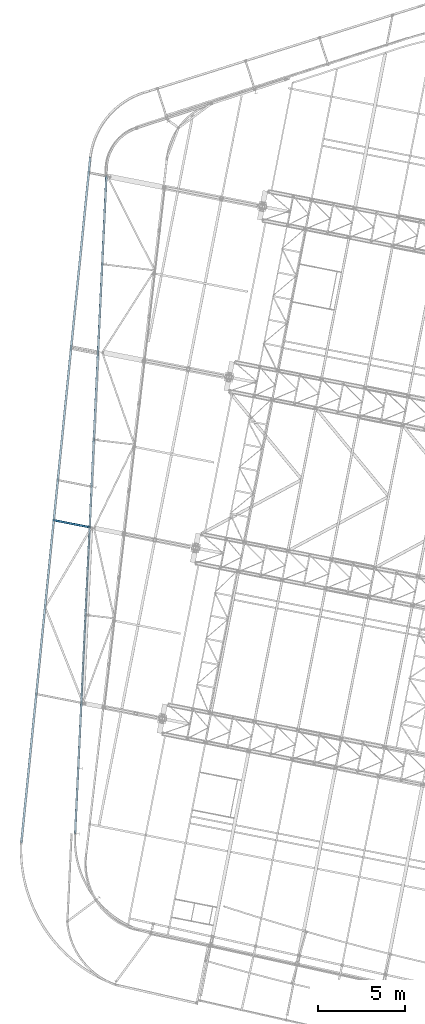
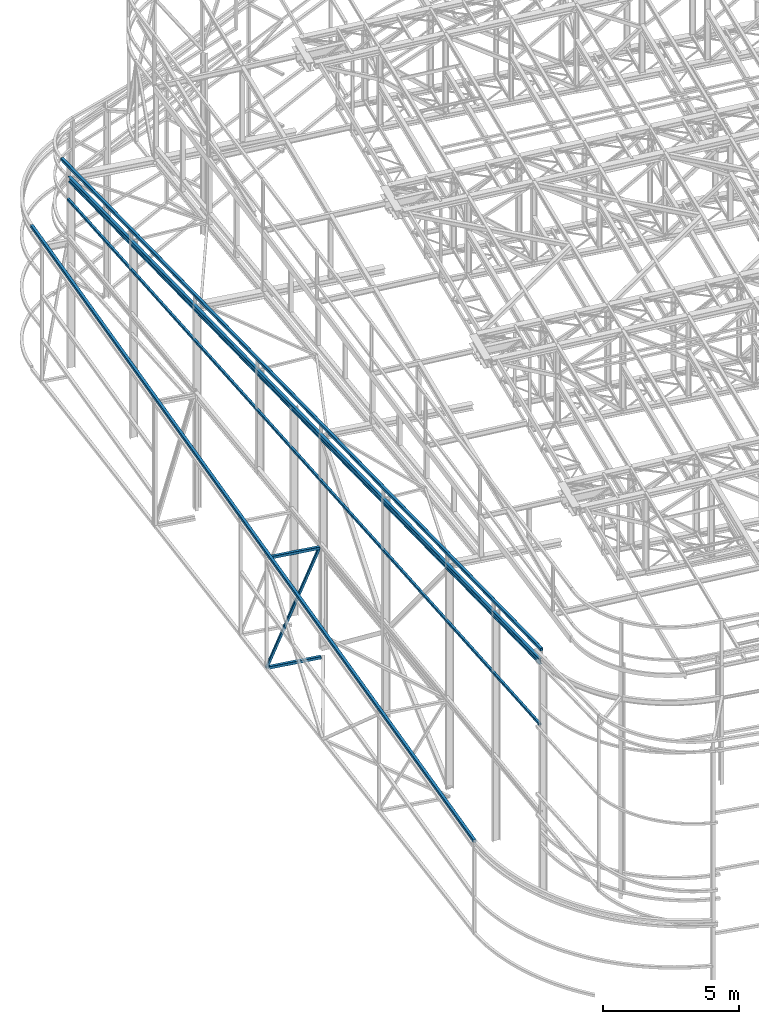
# One storey, part 64 of 215: 6 beams, 1 member, 7 elements without a shape of their own.
"""IFC2X3 building model written with IfcOpenShell, lengths in millimetres."""

from ifc_helpers import new_model, si_unit, frame, origin_with_axes, origin_2d_with_axis, place, context, subcontext, project, spatial, hollow_rectangle, i_section, extrude, material, type_object, element, aggregate, save


model = new_model("IFC2X3")

# Units and contexts
model_context = context("Model", 3, precision=1e-05, world=origin_with_axes())
body_context = subcontext(model_context, "Body", "Model", "MODEL_VIEW")
ifc_project = project(units=[si_unit("LENGTHUNIT", "METRE", prefix="MILLI"), si_unit("AREAUNIT", "SQUARE_METRE"), si_unit("VOLUMEUNIT", "CUBIC_METRE"), si_unit("MASSUNIT", "GRAM", prefix="KILO"), si_unit("TIMEUNIT", "SECOND"), si_unit("PLANEANGLEUNIT", "RADIAN"), si_unit("SOLIDANGLEUNIT", "STERADIAN"), si_unit("THERMODYNAMICTEMPERATUREUNIT", "DEGREE_CELSIUS"), si_unit("LUMINOUSINTENSITYUNIT", "LUMEN")], contexts=[model_context])

# Site, building, storey
site_placement = place(None, origin_with_axes())
site = spatial("IfcSite", under=ifc_project, at=site_placement, CompositionType="ELEMENT")
building_placement = place(site_placement, origin_with_axes())
building = spatial("IfcBuilding", under=site, at=building_placement, Name="Undefined", CompositionType="ELEMENT")
storey_placement = place(building_placement, origin_with_axes())
storey = spatial("IfcBuildingStorey", under=building, at=storey_placement, Name="Undefined", CompositionType="ELEMENT", Elevation=0.0)

# Assembly, beam
assembly_1_placement = place(storey_placement, origin_with_axes())
assembly_1 = element("IfcElementAssembly", 1, at=assembly_1_placement, inside=storey, Name="Steel Assembly", AssemblyPlace="NOTDEFINED", PredefinedType="RIGID_FRAME")
ifc_material = material(Name="STEEL/S275JR")
beam_type_1 = type_object("IfcBeamType", Name="IPE240", PredefinedType="NOTDEFINED")
beam_1_placement = place(assembly_1_placement, frame((37244.8718975773, 16568.7108386803, 10402.3701338187), z_axis=(0.00235880600061508, 0.0493175830129321, 0.998780362261901), x_axis=(0.0475433059778084, 0.99764815753433, -0.0493739589769538)))
beam_1 = element("IfcBeam", 2, at=beam_1_placement, type_object=beam_type_1, material=ifc_material, Name="LISSE", ObjectType="IPE240", context=body_context, shape_type="SweptSolid", body=[
    extrude(i_section(OverallWidth=120.0, OverallDepth=240.0, WebThickness=6.199999809, FlangeThickness=9.800000191, FilletRadius=15.0, at=origin_2d_with_axis()), frame((37819.5155899821, -1.47177935104382e-13, -2.62425606176051e-13), z_axis=(-1.0, 0.0, 0.0), x_axis=(-6.93889390390723e-18, -1.0, -3.46944695195361e-18)), (0.0, 0.0, 1.0), 37819.5),
])
aggregate(assembly_1, [beam_1])

assembly_2_placement = place(storey_placement, origin_with_axes())
assembly_2 = element("IfcElementAssembly", 3, at=assembly_2_placement, inside=storey, Name="Steel Assembly", AssemblyPlace="NOTDEFINED", PredefinedType="RIGID_FRAME")
beam_type_2 = type_object("IfcBeamType", PredefinedType="NOTDEFINED")
beam_2_placement = place(assembly_2_placement, frame((34149.1191373452, 16048.7739430814, 3742.45813808884), z_axis=(0.994981514571063, -0.100058910956865, 0.0), x_axis=(0.0998888689606629, 0.993290622608835, 0.0582748049770509)))
beam_2 = element("IfcBeam", 4, at=beam_2_placement, type_object=beam_type_2, material=ifc_material, Name="LISSE", context=body_context, shape_type="SweptSolid", body=[
    extrude(hollow_rectangle(XDim=120.0, YDim=120.0, WallThickness=4.0, InnerFilletRadius=4.0, OuterFilletRadius=8.0, at=origin_2d_with_axis()), frame((39666.4637966155, 4.54747350886464e-13, -2.49233572426971e-13), z_axis=(-1.0, 0.0, 0.0), x_axis=(-6.93889390390723e-18, -1.0, -3.46944695195361e-18)), (0.0, 0.0, 1.0), 39666.5),
])
aggregate(assembly_2, [beam_2])

assembly_3_placement = place(storey_placement, origin_with_axes())
assembly_3 = element("IfcElementAssembly", 5, at=assembly_3_placement, inside=storey, Name="Steel Assembly", AssemblyPlace="NOTDEFINED", PredefinedType="RIGID_FRAME")
beam_3_placement = place(assembly_3_placement, frame((37240.9799916972, 16485.8746585333, 10991.8441871799), z_axis=(0.998870920963872, -0.0474969269982821, -0.000961861999965319), x_axis=(0.0473891229994004, 0.997618619987376, -0.0501134719993658)))
beam_3 = element("IfcBeam", 6, at=beam_3_placement, type_object=beam_type_2, material=ifc_material, Name="LISSE", context=body_context, shape_type="SweptSolid", body=[
    extrude(hollow_rectangle(XDim=120.0, YDim=120.0, WallThickness=4.0, InnerFilletRadius=4.0, OuterFilletRadius=8.0, at=origin_2d_with_axis()), frame((38483.0306597107, 1.55195973669731e-12, 9.49207018875676e-14), z_axis=(-1.0, 0.0, 0.0), x_axis=(-6.93889390390723e-18, -1.0, -3.46944695195361e-18)), (0.0, 0.0, 1.0), 38483.0),
])
aggregate(assembly_3, [beam_3])

assembly_4_placement = place(storey_placement, origin_with_axes())
assembly_4 = element("IfcElementAssembly", 7, at=assembly_4_placement, inside=storey, Name="Steel Assembly", AssemblyPlace="NOTDEFINED", PredefinedType="RIGID_FRAME")
beam_type_3 = type_object("IfcBeamType", PredefinedType="NOTDEFINED")
beam_4_placement = place(assembly_4_placement, frame((36077.572611903, 34575.0879245013, -375.378507601517), z_axis=(0.0, 0.0, 1.0), x_axis=(0.981422409205525, -0.19185946604018, 1.89999991602007e-08)))
beam_4 = element("IfcBeam", 8, at=beam_4_placement, type_object=beam_type_3, material=ifc_material, Name="POUTRE", context=body_context, shape_type="SweptSolid", body=[
    extrude(hollow_rectangle(XDim=120.0, YDim=120.0, WallThickness=5.0, InnerFilletRadius=5.0, OuterFilletRadius=10.0, at=origin_2d_with_axis()), frame((2047.58475878097, -5.68318936017544e-14, 0.0), z_axis=(-1.0, 0.0, 0.0), x_axis=(-6.93889390390723e-18, -1.0, -3.46944695195361e-18)), (0.0, 0.0, 1.0), 2047.6),
])
aggregate(assembly_4, [beam_4])

assembly_5_placement = place(storey_placement, origin_with_axes())
assembly_5 = element("IfcElementAssembly", 9, at=assembly_5_placement, inside=storey, Name="Steel Assembly", AssemblyPlace="NOTDEFINED", PredefinedType="RIGID_FRAME")
beam_5_placement = place(assembly_5_placement, frame((36077.5332269981, 34574.9691921142, 4547.03321998367), z_axis=(0.0, 0.0, 1.0), x_axis=(0.981475008651648, -0.191590206932, 0.0)))
beam_5 = element("IfcBeam", 10, at=beam_5_placement, type_object=beam_type_3, material=ifc_material, Name="POUTRE", context=body_context, shape_type="SweptSolid", body=[
    extrude(hollow_rectangle(XDim=120.0, YDim=120.0, WallThickness=5.0, InnerFilletRadius=5.0, OuterFilletRadius=10.0, at=origin_2d_with_axis()), frame((1995.05668038434, 5.53739465498732e-14, 0.0), z_axis=(-1.0, 0.0, 0.0), x_axis=(-6.93889390390723e-18, -1.0, -3.46944695195361e-18)), (0.0, 0.0, 1.0), 1995.1),
])
aggregate(assembly_5, [beam_5])

assembly_6_placement = place(storey_placement, origin_with_axes())
assembly_6 = element("IfcElementAssembly", 11, at=assembly_6_placement, inside=storey, Name="Steel Assembly", AssemblyPlace="NOTDEFINED", PredefinedType="RIGID_FRAME")
beam_type_4 = type_object("IfcBeamType", PredefinedType="NOTDEFINED")
beam_6_placement = place(assembly_6_placement, frame((37236.2204261589, 16597.2250197627, 7572.88877006101), z_axis=(3.64340000136608e-05, -1.73599999892668e-06, 0.999999999334775), x_axis=(0.0475972750198219, 0.998866607415969, 0.0)))
beam_6 = element("IfcBeam", 12, at=beam_6_placement, type_object=beam_type_4, material=ifc_material, Name="LISSE", context=body_context, shape_type="SweptSolid", body=[
    extrude(hollow_rectangle(XDim=100.0, YDim=100.0, WallThickness=5.0, InnerFilletRadius=5.0, OuterFilletRadius=10.0, at=origin_2d_with_axis()), frame((37837.7456697626, -2.62552102765508e-13, 8.01245430802941e-18), z_axis=(-1.0, 0.0, 0.0), x_axis=(-6.93889390390723e-18, -1.0, -3.46944695195361e-18)), (0.0, 0.0, 1.0), 37837.7),
])
aggregate(assembly_6, [beam_6])

# Assembly, member
assembly_7_placement = place(storey_placement, origin_with_axes())
assembly_7 = element("IfcElementAssembly", 13, at=assembly_7_placement, inside=storey, Name="Steel Assembly", AssemblyPlace="NOTDEFINED", PredefinedType="RIGID_FRAME")
member_type = type_object("IfcMemberType", PredefinedType="NOTDEFINED")
member_placement = place(assembly_7_placement, frame((36018.6885620023, 34586.5645163283, -375.378507607838), z_axis=(-0.905713799263292, 0.176799839051396, 0.385258784111996), x_axis=(0.378121276959571, -0.0738148379921079, 0.922808576901332)))
member = element("IfcMember", 14, at=member_placement, type_object=member_type, material=ifc_material, Name="POUTRE", context=body_context, shape_type="SweptSolid", body=[
    extrude(hollow_rectangle(XDim=100.0, YDim=100.0, WallThickness=5.0, InnerFilletRadius=5.0, OuterFilletRadius=10.0, at=origin_2d_with_axis()), frame((5334.16339162408, -6.40275842181319e-14, 0.0), z_axis=(-1.0, 0.0, 0.0), x_axis=(-6.93889390390723e-18, -1.0, -3.46944695195361e-18)), (0.0, 0.0, 1.0), 5334.2),
])
aggregate(assembly_7, [member])

save(model, "model.ifc")
